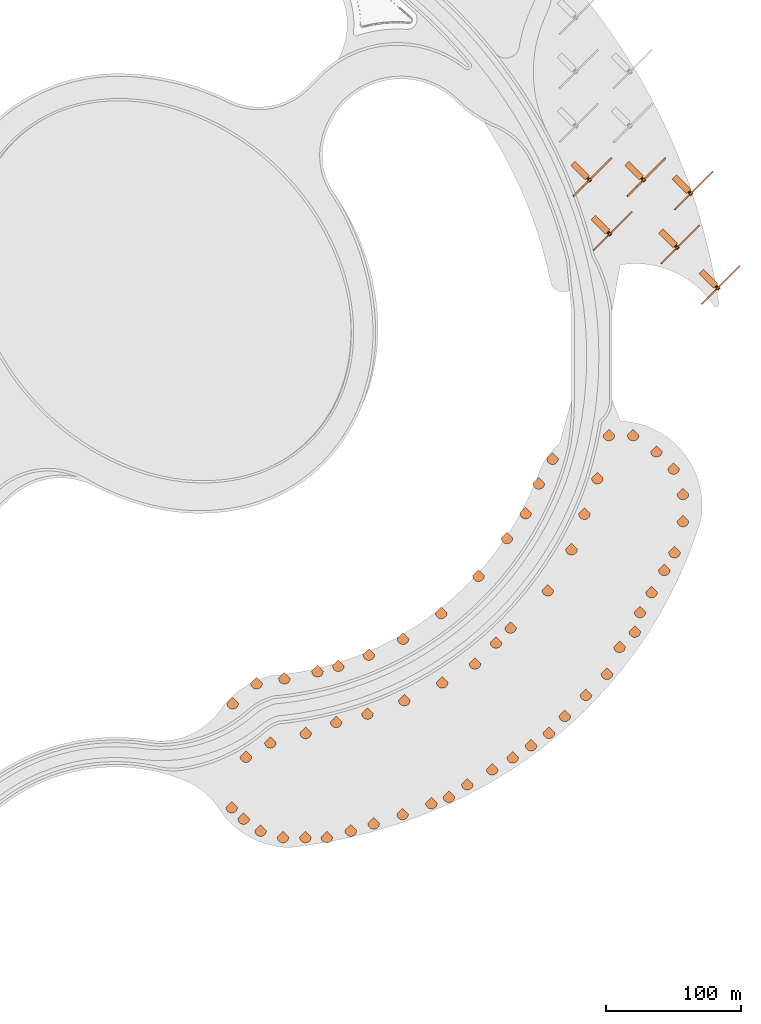
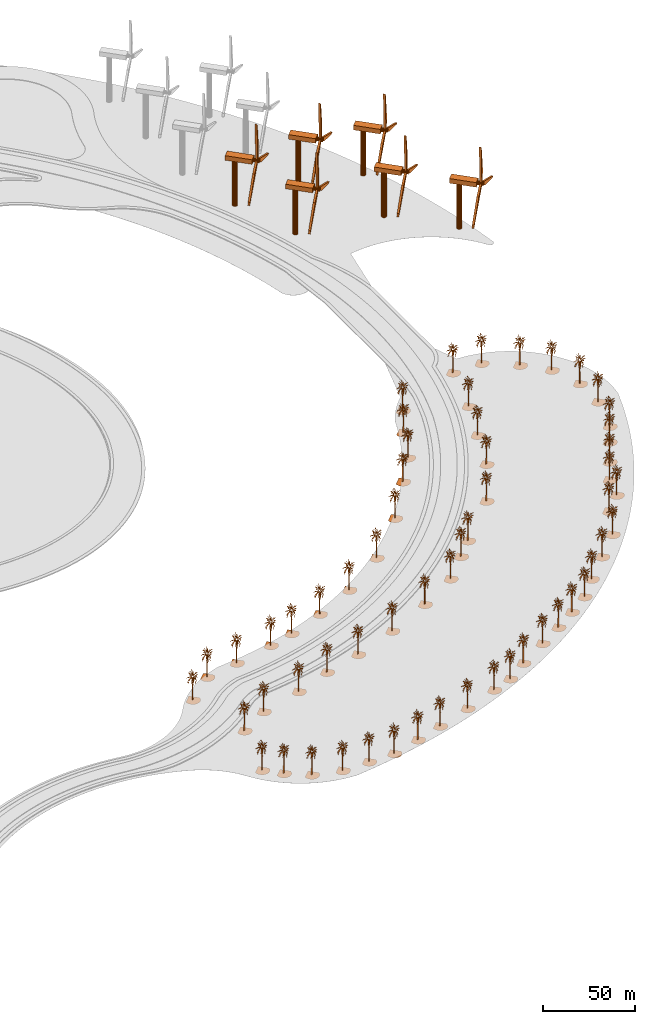
# One storey, part 20 of 39: 64 proxies.
"""IFC2X3 building model written with IfcOpenShell, lengths in millimetres."""

from ifc_helpers import new_model, entity, si_unit, converted_unit, derived_unit, direction, frame, frame_2d, origin, origin_2d_with_axis, place, context, subcontext, project, spatial, polyline, rectangle, circle, outline, extrude, face_set, surface_model, source, transform, mapped, material, element, save


model = new_model("IFC2X3")

# Units and contexts
model_context = context("Model", 3, precision=1e-06, world=origin(), true_north=direction((2.0, 6.12303176911189e-17, 1.0)))
context_of_model = context(None, 3, precision=1e-06, world=origin(), true_north=direction((2.0, 6.12303176911189e-17, 1.0)))
body_context = subcontext(model_context, "Body", "Model", "MODEL_VIEW")
ifc_project = project(units=[si_unit("LENGTHUNIT", "METRE", prefix="MILLI"), si_unit("AREAUNIT", "SQUARE_METRE", prefix="MILLI"), si_unit("VOLUMEUNIT", "CUBIC_METRE", prefix="MILLI"), converted_unit("PLANEANGLEUNIT", "DEGREE", entity("IfcRatioMeasure", 0.0174532925199433), si_unit("PLANEANGLEUNIT", "RADIAN"), dimensions=[0, 0, 0, 0, 0, 0, 0]), si_unit("MASSUNIT", "GRAM", prefix="KILO"), si_unit("TIMEUNIT", "SECOND"), si_unit("THERMODYNAMICTEMPERATUREUNIT", "KELVIN"), derived_unit("THERMALTRANSMITTANCEUNIT", [(si_unit("MASSUNIT", "GRAM", prefix="KILO"), 1), (si_unit("THERMODYNAMICTEMPERATUREUNIT", "KELVIN"), -1), (si_unit("TIMEUNIT", "SECOND"), -3)]), derived_unit("VOLUMETRICFLOWRATEUNIT", [(si_unit("LENGTHUNIT", "METRE"), 3), (si_unit("TIMEUNIT", "SECOND"), -1)])], contexts=[model_context, context_of_model])

# Site, building, storey
site_placement = place(None, origin())
site = spatial("IfcSite", under=ifc_project, at=site_placement, CompositionType="ELEMENT")
building_placement = place(site_placement, origin())
building = spatial("IfcBuilding", under=site, at=building_placement, CompositionType="ELEMENT")
storey_placement = place(building_placement, frame((0.0, 0.0, 4000.0)))
storey = spatial("IfcBuildingStorey", under=building, at=storey_placement, Name="Level 2", CompositionType="ELEMENT", Elevation=4000.0)

# Proxies
ifc_material = material(Name="Fiber")
shared_shape_1 = source(origin(), body_context, "Body", "SweptSolid", [
    extrude(circle(Radius=1219.2, at=frame_2d((-6.76791955811495e-14, 0.0), x_axis=(1.0, 0.0))), frame((9757.6692079255, 232.615468373865, 32004.0), z_axis=(1.0, 0.0, 0.0), x_axis=(0.0, 1.0, 0.0)), (0.0, 0.0, 1.0), 3530.39369698097),
    extrude(outline(polyline([(-25235.4928838689, -504.733169788446), (-23497.3886370042, -1390.34151744038), (-7977.11862314176, -3021.5876283642), (53.6807312814044, -2015.04698959787), (16924.7516619105, -20107.0555602115), (16387.0603591711, -18231.9031447106), (6995.27954346578, -5768.58904743497), (751.216457059019, -669.077510465183), (8466.50028987177, 23076.1245264183), (7087.13294967557, 21696.757186222), (739.698514629178, 7440.18602516133), (-695.320363049468, -504.733169788446), (-25235.4928838689, -504.733169788446)])), frame((11244.2702506938, 1002.10079122165, 31247.797146957), z_axis=(-1.0, 0.0, 0.0), x_axis=(0.0, 0.694658370459002, 0.719339800338647)), (0.0, 0.0, -1.0), 1219.2),
    extrude(rectangle(XDim=4611.80210432249, YDim=15240.0, at=origin_2d_with_axis()), frame((2137.6692079255, 256.362690579343, 30480.0), z_axis=(0.0, 0.0, 1.0), x_axis=(0.0, 1.0, 0.0)), (0.0, 0.0, 1.0), 3048.0),
    extrude(circle(Radius=1524.0, at=frame_2d((0.0, -2.47029063871196e-12), x_axis=(1.0, 0.0))), frame((-559.015649158661, 286.937889183146, 0.0)), (0.0, 0.0, 1.0), 30480.0),
])
for number, where, z_axis, x_axis, name in (
    (1, (496980.904039215, 486168.888693961, 0.0), (0.0, 0.0, 1.0), (0.707106781186547, -0.707106781186548, 0.0), "140_ft_tall_Wind_7978:140_ft_tall_Wind_7978"),
    (2, (536980.904039214, 486168.888693961, 0.0), (0.0, 0.0, 1.0), (0.707106781186547, -0.707106781186548, 0.0), "140_ft_tall_Wind_7978:140_ft_tall_Wind_7978"),
    (3, (571980.904039214, 476168.888693961, 0.0), (0.0, 0.0, 1.0), (0.707106781186547, -0.707106781186548, 0.0), "140_ft_tall_Wind_7978:140_ft_tall_Wind_7978"),
    (4, (511980.904039214, 446168.888693961, 0.0), (0.0, 0.0, 1.0), (0.707106781186547, -0.707106781186548, 0.0), "140_ft_tall_Wind_7978:140_ft_tall_Wind_7978"),
    (5, (561980.904039214, 436168.888693961, 0.0), (0.0, 0.0, 1.0), (0.707106781186547, -0.707106781186548, 0.0), "140_ft_tall_Wind_7978:140_ft_tall_Wind_7978"),
    (6, (591980.904039215, 406168.888693962, 0.0), (0.0, 0.0, 1.0), (0.707106781186547, -0.707106781186548, 0.0), "140_ft_tall_Wind_7978:140_ft_tall_Wind_7978"),
):
    element("IfcBuildingElementProxy", number, at=place(storey_placement, frame(where, z_axis=z_axis, x_axis=x_axis)), inside=storey, material=ifc_material, Name=name, ObjectType="140_ft_tall_Wind_7978", CompositionType="ELEMENT", context=body_context, shape_type="MappedRepresentation", body=[
        mapped(shared_shape_1, transform((0.0, 0.0, 0.0), scale=1.0)),
    ])
shared_shape_2 = source(origin(), body_context, "Body", "SurfaceModel", [
    surface_model("IfcFaceBasedSurfaceModel", [(1614.98165588379, -0.0491518181632273, 17645.1159851074), (2518.84770584106, -0.0492362198419869, 17896.1820556641), (1866.05484809876, -0.0491448190645315, 17544.7162994385), (259.179746818542, -0.0492452193167992, 18498.7813201904), (8.10526300817728, -0.0494048191700131, 19452.8475036621), (510.254174423218, -0.0492561526363716, 18498.7813201904), (-2854.1403213501, -0.0481034170486964, 12874.7211181641), (-3255.85998687744, -0.0478972851647995, 11820.1878112793), (-3105.22005386353, -0.0482002201722935, 13477.2529449463), (-2050.70128097534, -0.0481834853184409, 13125.7871887207), (-2753.71389312744, -0.0478025533840992, 11167.3892852783), (-594.47272567749, -0.0479866855661385, 11669.5214263916), (-845.549188041687, -0.0479218840249814, 11368.2549316406), (-544.258784866333, -0.0481325533473864, 12472.9875), (2468.6342010498, -0.0481744858436286, 11970.8553588867), (2267.77436828613, -0.0480489544803277, 11318.055670166), (1966.48796195984, -0.0482962204841897, 12774.253994751), (2167.34779472351, -0.0483139533083886, 12824.5206939697), (-343.398298072815, -0.0478809539345093, 11016.7229003906), (-745.115928840637, -0.047809552482795, 10715.4564056396), (-544.259438896179, -0.0479350173147395, 11368.2549316406), (2669.49403381348, -0.0486681529437192, 14682.4526367188), (2970.78058547974, -0.0485286854789592, 13828.786138916), (2368.20762748718, -0.0485741530079395, 14230.5197570801), (2518.84770584106, -0.0489040199085139, 16038.2512756348), (3623.57998352051, -0.0488894184934907, 15686.718081665), (2669.49403381348, -0.0487848844262771, 15335.2511627197), (-745.115928840637, -0.049048619158566, 17645.1159851074), (-544.258784866333, -0.0491831499966793, 18348.1149353027), (-192.754477214813, -0.0490458825021051, 17494.4496002197), (2920.56708068848, -0.0491998848505318, 17594.9155609131), (3472.93336486816, -0.0491791492444463, 17343.8494903564), (2820.14065246582, -0.0491146847954951, 17142.9826812744), (-3055.00015411377, -0.0485974833369255, 15686.718081665), (-4109.51253204346, -0.0485064861830324, 15435.6508483887), (-3808.2259803772, -0.0486094855936244, 15937.7841522217), (-2753.71389312744, -0.0487004871829413, 16188.9176605225), (-1648.98844642639, -0.0488385530537926, 16691.0498016357), (-2351.99437294006, -0.048852684313897, 16942.1170349121), (-1448.12861366272, -0.0489730173605494, 17394.0499145508), (1363.90860900879, -0.0486020873067901, 14632.2522125244), (1715.40822944641, -0.0485815512947738, 14431.3854034424), (1464.33518257141, -0.0485526190255769, 14330.919442749), (2066.91453552246, -0.049117683141958, 17343.8494903564), (2368.20762748718, -0.049041083373595, 16841.649911499), (-1598.76840133667, -0.0487778853275813, 16339.516607666), (-1900.06149330139, -0.0487826844560914, 16439.9837310791), (-745.115928840637, -0.0489768185187131, 17243.3823669434), (-42.1100204944611, -0.0488369518658146, 16289.3173461914), (-2753.71389312744, -0.04914041912416, 18649.4477050781), (-2803.92710723877, -0.0492190192686394, 19101.3805847168), (-2351.99437294006, -0.0492298195254989, 19051.113885498), (1614.98165588379, -0.0490620185737498, 17142.9826812744), (962.189016151428, -0.0490334854926914, 17142.9826812744), (-2603.0672744751, -0.0485813517007045, 15485.851272583), (-1598.76840133667, -0.0487240171059966, 16038.2512756348), (-1548.55518722534, -0.0486364174867049, 15536.1179718018), (-845.549188041687, -0.0486940868664533, 15686.718081665), (-895.762474822998, -0.0486290191998705, 15335.2511627197), (911.975729370117, -0.0488516863435507, 16138.6509613037), (208.964461612701, -0.048847885185387, 16289.3173461914), (-1950.27470741272, -0.0490318843047135, 17845.9827941895), (-1598.76840133667, -0.0491460166289471, 18398.3153594971), (-1197.04880847931, -0.0490468183765188, 17745.5156707764), (2117.12789497375, -0.0487158204428852, 15084.1850921631), (2016.70132141113, -0.0485857516410761, 14381.1187042236), (1614.98165588379, -0.0486579514690675, 14883.3182830811), (1614.98165588379, -0.0488375506480224, 15887.5837280273), (1213.26213569641, -0.0488110179430805, 15837.3844665527), (208.964461612701, -0.0490813525859267, 17594.9155609131), (660.899339675903, -0.0490652165142819, 17394.0499145508), (1715.40822944641, -0.048419884534087, 13527.519644165), (2267.77436828613, -0.0483632175601088, 13075.5867645264), (1966.48796195984, -0.048448816803284, 13627.919329834), (-996.195734024048, -0.0487323512672447, 15937.7841522217), (-2301.78101348877, -0.0484148858115077, 14481.5858276367), (-1498.34182777405, -0.0483782181632705, 14079.8522094727), (-192.754477214813, -0.0485968845547177, 14983.71796875), (309.394377994537, -0.0478915545972995, 10916.322052002), (359.609009170532, -0.045945286215283, 0.00245501093304483), (-142.539855122566, -0.045908019784838, 0.00247696434016689), (-393.614273643494, -0.0459302856121212, 0.0024879375785531), (-343.398988437653, -0.047081819199957, 6547.63347930908), (1263.47534980774, -0.0485348196700215, 14280.7190185547), (1966.48796195984, -0.0484757531317882, 13778.5868774414), (811.542470169067, -0.0485510178375989, 14481.5858276367), (1614.98165588379, -0.048631019575987, 14732.6518981934), (-293.184375429153, -0.0484039524919353, 13929.185824585), (761.329256057739, -0.0483692186884582, 13477.2529449463), (-694.902642059326, -0.0482786207227036, 13326.6539978027), (-393.613583278656, -0.0482199533726089, 12924.9203796387), (761.329256057739, -0.0481716870912351, 12372.5878143311), (510.254174423218, -0.0479452187893912, 11167.3892852783), (0.186937161767855, -7.72852592021227, 19076.9809112549), (0.186943495552987, -784.992564582825, 19999.9792236328), (0.186939290771261, -444.941554927826, 19562.7803283691), (0.186941827833653, -1319.36539764404, 12470.1876708984), (0.186935884365812, -1319.36539764404, 10381.3233123779), (0.186941561708227, -1173.63214187622, 11450.0557525635), (0.186943016527221, 2858.44383773804, 11790.1222045898), (0.186937623051926, 3441.38994140625, 10867.1227294922), (0.186941153649241, 2761.28407058716, 12713.1205169678), (0.186935689207166, -2582.42405776978, 17279.5162078857), (0.186940284306183, -4039.8025428772, 16890.9166717529), (0.186938616586849, -2776.74388275146, 16890.9166717529), (0.186938758520409, -1027.89234580994, 12324.4547058105), (0.186939893988892, 575.221429824829, 10964.2563354492), (0.186944950371981, 1061.0122718811, 9944.05697937012), (0.186941153649241, 1061.0122718811, 11158.588659668), (0.186937818210572, -153.465850639343, 18153.9814361572), (0.186938421428204, 2761.28407058716, 16988.05027771), (0.18694294556044, 3635.70976638794, 17085.2501586914), (0.18694069236517, 2761.28407058716, 17473.8496948242), (0.186942022992298, 2081.17790908814, 12761.6536010742), (0.186939823022112, 2907.02372131348, 14704.852432251), (0.186939947213978, 3830.02959136963, 14219.0530151367), (0.186936948867515, 3344.23656921387, 15287.7842926025), (0.186942679435015, -590.678734874725, 11109.9893005371), (0.186935689207166, -1027.89234580994, 9652.59046783447), (0.1869391488377, -590.678734874725, 9944.05697937012), (0.186937427893281, -153.465850639343, 10769.9228485107), (0.186941295582801, -3116.79696350098, 15773.5848724365), (0.18694294556044, -3748.32295074463, 15142.0513275147), (0.18693689564243, -3019.63690567017, 15142.0513275147), (0.186941827833653, 1401.06520729065, 19076.9809112549), (0.186939823022112, 915.272403144837, 19951.379864502), (0.186941827833653, 818.119176292419, 19659.9139343262), (0.186936558550224, 1109.59222812653, 16210.7837677002), (0.186936026299372, 2081.17790908814, 16745.183706665), (0.186944347154349, 1692.54494476318, 16890.9166717529), (0.186942093959078, 2809.8639541626, 15287.7842926025), (0.186937356926501, -1222.2054851532, 17911.0485900879), (0.186936221458018, -2048.05129737854, 18494.0478881836), (0.186936079524457, -2048.05129737854, 18056.7815551758), (0.186938084335998, -1805.15827445984, 17425.3166107178), (0.186941224616021, -3602.58969497681, 13004.5876098633), (0.186942218150944, -3165.37684707642, 12373.0540649414), (0.186941029457375, -2339.53103485107, 14121.9194091797), (0.186941685900092, -3262.53690490723, 13976.1864440918), (0.186938492394984, -1562.26510620117, 15239.2512084961), (0.186941756866872, -1173.63214187622, 15142.0513275147), (0.186940355272964, 2324.0710773468, 13781.8529571533), (0.186935955332592, 1401.06520729065, 14170.4524932861), (0.186940355272964, 1352.48532371521, 14753.4517913818), (0.186938084335998, 1012.43231563568, 14607.7188262939), (0.186941561708227, 575.221429824829, 19028.381552124), (0.186940213339403, 1741.12497367859, 17182.3826019287), (0.186935547273606, 915.272403144837, 16599.4507415771), (0.186942555243149, -2096.63118095398, 15433.5184204102), (0.186939627863467, -2193.79109344482, 16113.6501617432), (0.186938758520409, -1465.10519371033, 16016.5177185059), (0.186941348807886, 1303.91198043823, 17862.5155059814), (0.186940887523815, -1950.89807052612, 16550.8502197266), (0.186943158460781, -1756.57824554443, 16842.3161499023), (0.186937960144132, -1222.2054851532, 16405.1172546387), (0.186935955332592, -1222.2054851532, 16793.7830657959), (0.186937356926501, -639.25800075531, 17328.1155670166), (0.186944613279775, -299.204374980927, 16502.2508605957), (0.186943158460781, -250.625090932846, 6009.17390441895), (0.186936558550224, -250.625090932846, 0.00121222543166368), (0.18693882948719, 235.167095518112, 0.0012990920971788), (0.186937818210572, 429.48424987793, 0.00133383865249925), (0.186938758520409, 429.48424987793, 4794.69512786865), (0.186944081028923, 380.905638027191, 11255.722265625), (0.186940621398389, 2372.65096092224, 14607.7188262939), (0.186941224616021, 2615.54412918091, 16113.6501617432), (0.186939823022112, 1692.54494476318, 15919.3178375244), (0.186936221458018, 1789.6981716156, 14656.2519104004), (0.186938013369218, -639.25800075531, 13004.5876098633), (0.186942413309589, -1076.47222938538, 13976.1864440918), (0.186937552085146, -202.045134687424, 17328.1155670166), (0.186936079524457, 40.8505588531494, 15967.9171966553), (0.186940018180758, -542.099468994141, 12518.7870300293), (0.186941881058738, 1206.75214061737, 13198.919934082), (0.186944151995704, -299.204374980927, 15190.6518493652), (0.186939893988892, -1465.10519371033, 16259.3842895508), (4315.3458984375, -128.947870445251, 0.00104536562139401), (-11.6471167892218, 4198.04259338379, 0.000794539219714352), (-4338.63895339966, -128.947870445251, 0.00142363851919072), (4200.95259017944, -1120.40552158356, 0.000873079139455513), (-4224.2456451416, -1120.40552158356, 0.00124135216647119), (3875.16637115479, -2030.90466957092, 0.000724505957623478), (-3898.45942611694, -2030.90466957092, 0.00106430564319453), (-3387.36649475098, -2834.3572265625, 0.000898299097570998), (3364.07343978882, -2834.3572265625, 0.000603181385849894), (2693.76086654663, -3504.66979980469, 0.000512620150948351), (-2717.05392150879, -3504.66979980469, 0.000749132608507352), (-1913.60150985718, -4015.76273117065, 0.000622624065908894), (-1003.10904750824, -4341.54895019531, 0.000524569494427851), (-11.6463174194098, -4455.94225845337, 0.000460776873569557), (979.81570186615, -4341.54895019531, 0.000437893552134483), (1890.30816421509, -4015.76273117065, 0.000456349558317015)], [face_set([[[0, 1, 2]], [[3, 4, 5]], [[6, 7, 8]], [[9, 10, 6]], [[11, 12, 13]], [[14, 15, 16]], [[17, 14, 16]], [[18, 19, 20]], [[21, 22, 23]], [[24, 25, 26]], [[27, 28, 29]], [[30, 31, 32]], [[33, 34, 35]], [[33, 35, 36]], [[37, 38, 39]], [[40, 41, 42]], [[43, 30, 32]], [[43, 32, 44]], [[45, 46, 37]], [[47, 27, 29]], [[47, 29, 48]], [[49, 50, 51]], [[0, 2, 52]], [[53, 0, 52]], [[54, 33, 36]], [[54, 36, 55]], [[56, 54, 55]], [[56, 55, 57]], [[58, 56, 57]], [[43, 44, 59]], [[52, 43, 59]], [[60, 53, 59]], [[61, 49, 51]], [[61, 51, 62]], [[61, 62, 63]], [[39, 61, 63]], [[39, 63, 47]], [[64, 21, 23]], [[64, 23, 65]], [[64, 65, 66]], [[67, 24, 26]], [[67, 26, 64]], [[68, 67, 66]], [[69, 3, 5]], [[69, 5, 70]], [[48, 69, 70]], [[48, 70, 60]], [[17, 16, 71]], [[72, 17, 71]], [[73, 72, 71]], [[74, 45, 48]], [[57, 74, 48]], [[9, 8, 75]], [[76, 9, 75]], [[76, 75, 58]], [[77, 76, 58]], [[78, 79, 80]], [[78, 80, 81]], [[78, 81, 82]], [[78, 82, 18]], [[73, 71, 83]], [[84, 73, 83]], [[42, 84, 83]], [[40, 83, 85]], [[77, 59, 68]], [[77, 66, 86]], [[77, 86, 40]], [[87, 77, 85]], [[87, 85, 88]], [[89, 87, 88]], [[90, 89, 88]], [[90, 88, 91]], [[13, 90, 91]], [[13, 91, 92]], [[20, 11, 92]], [[78, 18, 92]], [[93, 94, 95]], [[96, 97, 98]], [[99, 100, 101]], [[102, 103, 104]], [[96, 98, 105]], [[106, 107, 108]], [[93, 95, 109]], [[110, 111, 112]], [[113, 99, 101]], [[114, 115, 116]], [[117, 118, 119]], [[117, 119, 120]], [[121, 122, 123]], [[124, 125, 126]], [[127, 128, 129]], [[114, 116, 130]], [[131, 132, 133]], [[131, 133, 134]], [[135, 136, 137]], [[138, 135, 137]], [[139, 138, 137]], [[139, 137, 140]], [[113, 101, 141]], [[142, 113, 141]], [[142, 141, 143]], [[144, 142, 143]], [[124, 126, 145]], [[110, 112, 146]], [[129, 110, 146]], [[129, 146, 147]], [[121, 123, 148]], [[149, 121, 148]], [[150, 149, 148]], [[150, 148, 139]], [[151, 124, 145]], [[102, 104, 152]], [[153, 102, 152]], [[153, 152, 154]], [[155, 153, 154]], [[131, 134, 155]], [[156, 131, 155]], [[157, 156, 155]], [[158, 159, 160]], [[158, 160, 161]], [[158, 161, 162]], [[158, 162, 163]], [[120, 158, 163]], [[164, 114, 130]], [[130, 165, 166]], [[167, 164, 166]], [[143, 167, 166]], [[96, 105, 168]], [[169, 96, 168]], [[145, 93, 109]], [[151, 109, 170]], [[147, 151, 170]], [[147, 170, 171]], [[172, 117, 163]], [[143, 166, 127]], [[163, 106, 108]], [[163, 108, 173]], [[168, 172, 173]], [[168, 173, 144]], [[174, 169, 144]], [[150, 140, 174]], [[150, 171, 157]], [[150, 154, 175]], [[176, 177, 178]], [[179, 176, 178]], [[179, 178, 180]], [[181, 179, 180]], [[181, 180, 182]], [[181, 182, 183]], [[184, 181, 183]], [[185, 184, 183]], [[185, 183, 186]], [[185, 186, 187]], [[185, 187, 188]], [[185, 188, 189]], [[185, 189, 190]], [[185, 190, 191]]])]),
])
for number, where, name in (
    (7, (240807.894644676, 13890.8738782972, 0.0), "M_RPC Tree - Tropical:Cuban Royal Palm - 7.5 Meters"),
    (8, (249654.788559023, 5412.60054371497, 0.0), "M_RPC Tree - Tropical:Cuban Royal Palm - 7.5 Meters"),
    (9, (262187.888271014, -3434.29337063169, 0.0), "M_RPC Tree - Tropical:Cuban Royal Palm - 7.5 Meters"),
    (10, (278775.814360414, -8226.36090756946, 0.0), "M_RPC Tree - Tropical:Cuban Royal Palm - 7.5 Meters"),
    (11, (295363.740449814, -8226.36090756946, 0.0), "M_RPC Tree - Tropical:Cuban Royal Palm - 7.5 Meters"),
    (12, (311214.425379685, -8226.36090756946, 0.0), "M_RPC Tree - Tropical:Cuban Royal Palm - 7.5 Meters"),
    (13, (388624.747130218, 16839.8385164127, 0.0), "M_RPC Tree - Tropical:Cuban Royal Palm - 7.5 Meters"),
    (14, (401526.467421973, 21631.9060533505, 0.0), "M_RPC Tree - Tropical:Cuban Royal Palm - 7.5 Meters"),
    (15, (415165.428873258, 30847.4205474616, 0.0), "M_RPC Tree - Tropical:Cuban Royal Palm - 7.5 Meters"),
    (16, (433596.45786148, 41906.0379403949, 0.0), "M_RPC Tree - Tropical:Cuban Royal Palm - 7.5 Meters"),
    (17, (448709.901631822, 50752.9318547416, 0.0), "M_RPC Tree - Tropical:Cuban Royal Palm - 7.5 Meters"),
    (18, (462356.882884595, 59704.553179678, 0.0), "M_RPC Tree - Tropical:Cuban Royal Palm - 7.5 Meters"),
    (19, (475627.223756115, 68920.0676737891, 0.0), "M_RPC Tree - Tropical:Cuban Royal Palm - 7.5 Meters"),
    (20, (487423.082308578, 81453.1673857802, 0.0), "M_RPC Tree - Tropical:Cuban Royal Palm - 7.5 Meters"),
    (21, (328916.233009867, -3434.29337063169, 0.0), "M_RPC Tree - Tropical:Cuban Royal Palm - 7.5 Meters"),
    (22, (345872.779679031, 1831.1221566602, 0.0), "M_RPC Tree - Tropical:Cuban Royal Palm - 7.5 Meters"),
    (23, (367252.773305369, 8834.91317218466, 0.0), "M_RPC Tree - Tropical:Cuban Royal Palm - 7.5 Meters"),
    (24, (502979.431494682, 97009.5165718842, 0.0), "M_RPC Tree - Tropical:Cuban Royal Palm - 7.5 Meters"),
    (25, (518535.780680786, 112565.865757988, 0.0), "M_RPC Tree - Tropical:Cuban Royal Palm - 7.5 Meters"),
    (26, (527833.382439081, 132504.637072795, 0.0), "M_RPC Tree - Tropical:Cuban Royal Palm - 7.5 Meters"),
    (27, (539147.090938066, 143818.345571779, 0.0), "M_RPC Tree - Tropical:Cuban Royal Palm - 7.5 Meters"),
    (28, (543029.376614604, 158307.232966115, 0.0), "M_RPC Tree - Tropical:Cuban Royal Palm - 7.5 Meters"),
    (29, (551529.376614604, 173029.664830451, 0.0), "M_RPC Tree - Tropical:Cuban Royal Palm - 7.5 Meters"),
    (30, (561029.376614604, 189484.147502355, 0.0), "M_RPC Tree - Tropical:Cuban Royal Palm - 7.5 Meters"),
    (31, (568529.376614604, 202474.528559122, 0.0), "M_RPC Tree - Tropical:Cuban Royal Palm - 7.5 Meters"),
    (32, (574741.033697064, 225656.748390059, 0.0), "M_RPC Tree - Tropical:Cuban Royal Palm - 7.5 Meters"),
    (33, (574741.033697064, 245656.748390059, 0.0), "M_RPC Tree - Tropical:Cuban Royal Palm - 7.5 Meters"),
    (34, (567900.630830551, 264450.600805777, 0.0), "M_RPC Tree - Tropical:Cuban Royal Palm - 7.5 Meters"),
    (35, (555172.708769193, 277178.522867135, 0.0), "M_RPC Tree - Tropical:Cuban Royal Palm - 7.5 Meters"),
    (36, (537970.515839124, 289223.628030507, 0.0), "M_RPC Tree - Tropical:Cuban Royal Palm - 7.5 Meters"),
    (37, (519970.515839124, 289223.628030507, 0.0), "M_RPC Tree - Tropical:Cuban Royal Palm - 7.5 Meters"),
    (38, (511429.487350741, 257348.075762968, 0.0), "M_RPC Tree - Tropical:Cuban Royal Palm - 7.5 Meters"),
    (39, (501852.923337622, 231036.682380963, 0.0), "M_RPC Tree - Tropical:Cuban Royal Palm - 7.5 Meters"),
    (40, (492276.359324503, 204725.288998957, 0.0), "M_RPC Tree - Tropical:Cuban Royal Palm - 7.5 Meters"),
    (41, (474776.359324503, 174414.399866502, 0.0), "M_RPC Tree - Tropical:Cuban Royal Palm - 7.5 Meters"),
    (42, (447199.194858228, 146837.235400227, 0.0), "M_RPC Tree - Tropical:Cuban Royal Palm - 7.5 Meters"),
    (43, (251262.09276501, 51272.3254002079, 0.0), "M_RPC Tree - Tropical:Cuban Royal Palm - 7.5 Meters"),
    (44, (269448.626244483, 61772.3254002079, 0.0), "M_RPC Tree - Tropical:Cuban Royal Palm - 7.5 Meters"),
    (45, (295528.623554288, 68760.439617976, 0.0), "M_RPC Tree - Tropical:Cuban Royal Palm - 7.5 Meters"),
    (46, (318081.246453149, 76968.923057792, 0.0), "M_RPC Tree - Tropical:Cuban Royal Palm - 7.5 Meters"),
    (47, (341263.466284087, 83180.5801402525, 0.0), "M_RPC Tree - Tropical:Cuban Royal Palm - 7.5 Meters"),
    (48, (368514.552286878, 93099.1642966969, 0.0), "M_RPC Tree - Tropical:Cuban Royal Palm - 7.5 Meters"),
    (49, (396610.093685014, 106200.330410659, 0.0), "M_RPC Tree - Tropical:Cuban Royal Palm - 7.5 Meters"),
    (50, (420858.804990979, 120200.330410658, 0.0), "M_RPC Tree - Tropical:Cuban Royal Palm - 7.5 Meters"),
    (51, (436415.154177083, 135756.679596763, 0.0), "M_RPC Tree - Tropical:Cuban Royal Palm - 7.5 Meters"),
    (52, (241541.141220036, 90766.4687279896, 0.0), "M_RPC Tree - Tropical:Cuban Royal Palm - 7.5 Meters"),
    (53, (259160.163411772, 105550.58375078, 0.0), "M_RPC Tree - Tropical:Cuban Royal Palm - 7.5 Meters"),
    (54, (279841.126225029, 109197.195481785, 0.0), "M_RPC Tree - Tropical:Cuban Royal Palm - 7.5 Meters"),
    (55, (304294.816243374, 114394.987752229, 0.0), "M_RPC Tree - Tropical:Cuban Royal Palm - 7.5 Meters"),
    (56, (319749.629463999, 118536.09247387, 0.0), "M_RPC Tree - Tropical:Cuban Royal Palm - 7.5 Meters"),
    (57, (342302.252362861, 126744.575913686, 0.0), "M_RPC Tree - Tropical:Cuban Royal Palm - 7.5 Meters"),
    (58, (367678.870399887, 138577.887242425, 0.0), "M_RPC Tree - Tropical:Cuban Royal Palm - 7.5 Meters"),
    (59, (395866.147866758, 157590.445960431, 0.0), "M_RPC Tree - Tropical:Cuban Royal Palm - 7.5 Meters"),
    (60, (423443.312333034, 185167.610426706, 0.0), "M_RPC Tree - Tropical:Cuban Royal Palm - 7.5 Meters"),
    (61, (444506.838143355, 213119.853278361, 0.0), "M_RPC Tree - Tropical:Cuban Royal Palm - 7.5 Meters"),
    (62, (458348.583675853, 231488.470009449, 0.0), "M_RPC Tree - Tropical:Cuban Royal Palm - 7.5 Meters"),
    (63, (468110.263109672, 253413.560992871, 0.0), "M_RPC Tree - Tropical:Cuban Royal Palm - 7.5 Meters"),
    (64, (478291.265134845, 271780.574842799, 0.0), "M_RPC Tree - Tropical:Cuban Royal Palm - 7.5 Meters"),
):
    element("IfcBuildingElementProxy", number, at=place(storey_placement, frame(where)), inside=storey, Name=name, ObjectType="Cuban Royal Palm - 7.5 Meters", CompositionType="ELEMENT", context=body_context, shape_type="MappedRepresentation", body=[
        mapped(shared_shape_2, transform((0.0, 0.0, 0.0), scale=1.0)),
    ])

save(model, "model.ifc")
